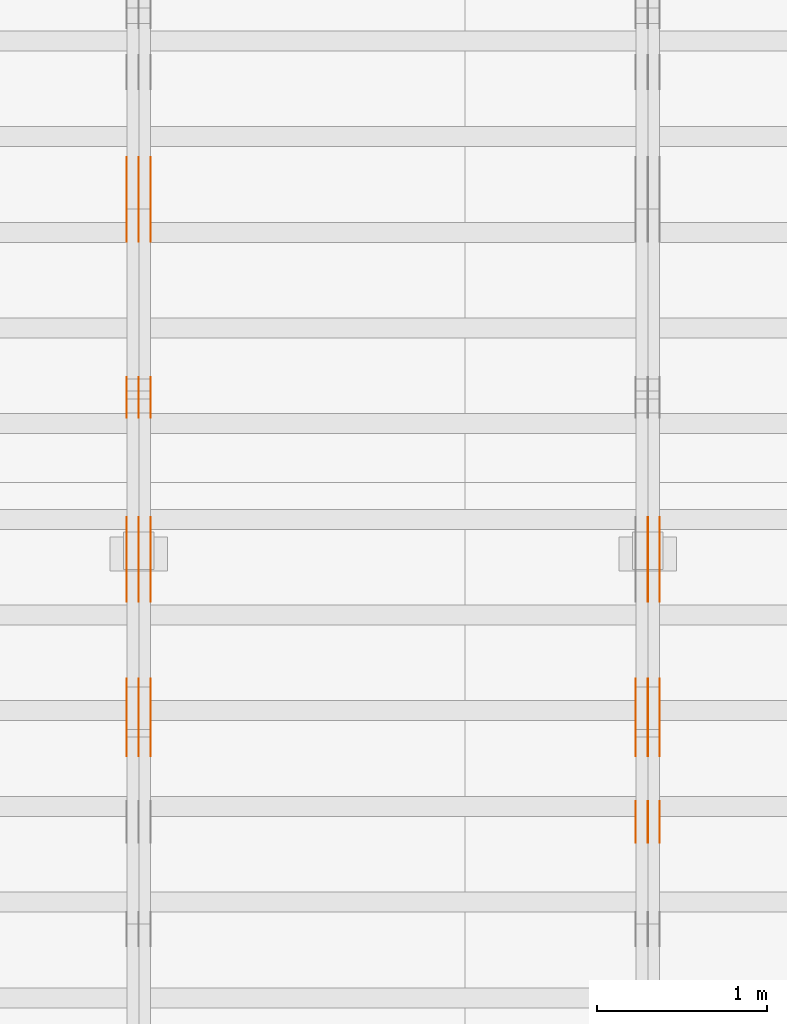
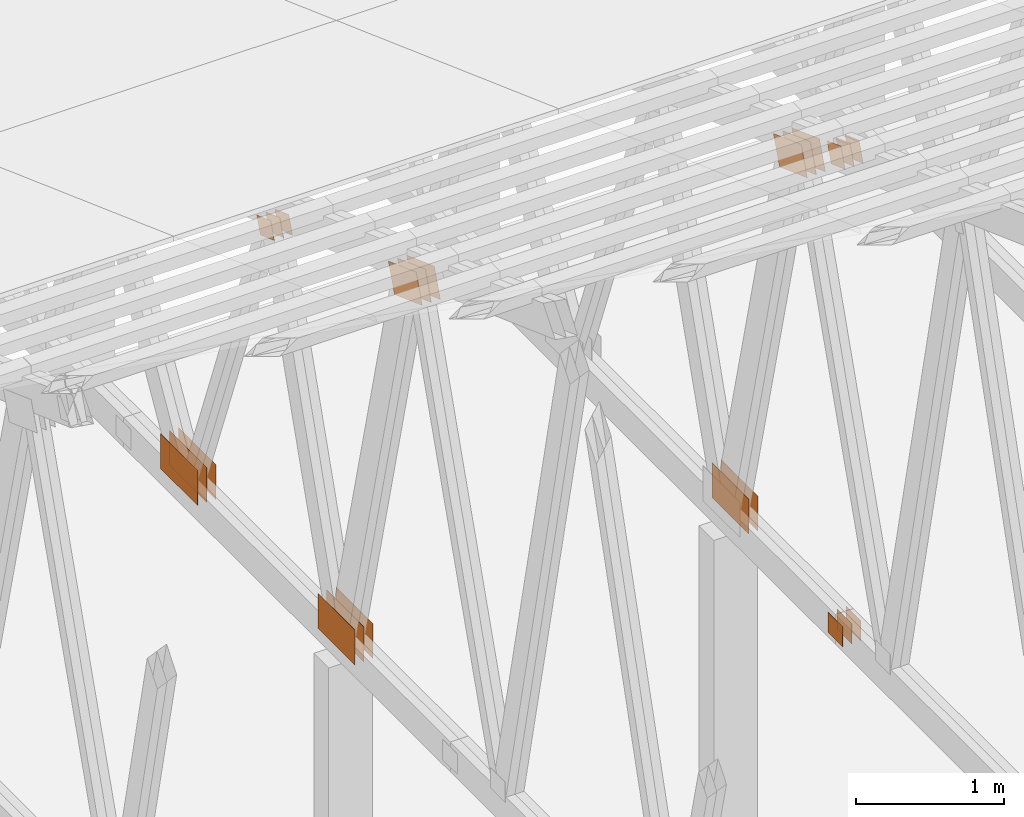
# One storey, part 160 of 189: 31 proxies.
"""IFC2X3 building model written with IfcOpenShell, lengths in millimetres."""

from ifc_helpers import new_model, entity, si_unit, converted_unit, derived_unit, direction, frame, origin, origin_2d_with_axis, place, context, subcontext, project, spatial, polyline, rectangle, outline, extrude, source, transform, mapped, material, type_object, type_shapes, element, save


model = new_model("IFC2X3")

# Units and contexts
model_context = context("Model", 3, precision=0.01, world=origin(), true_north=direction((6.12303176911189e-17, 1.0)))
body_context = subcontext(model_context, "Body", "Model", "MODEL_VIEW")
ifc_project = project(units=[si_unit("LENGTHUNIT", "METRE", prefix="MILLI"), si_unit("AREAUNIT", "SQUARE_METRE"), si_unit("VOLUMEUNIT", "CUBIC_METRE"), converted_unit("PLANEANGLEUNIT", "DEGREE", entity("IfcRatioMeasure", 0.0174532925199433), si_unit("PLANEANGLEUNIT", "RADIAN"), dimensions=[0, 0, 0, 0, 0, 0, 0]), si_unit("MASSUNIT", "GRAM", prefix="KILO"), derived_unit("MASSDENSITYUNIT", [(si_unit("MASSUNIT", "GRAM", prefix="KILO"), 1), (si_unit("LENGTHUNIT", "METRE"), -3)]), si_unit("TIMEUNIT", "SECOND"), si_unit("FREQUENCYUNIT", "HERTZ"), si_unit("THERMODYNAMICTEMPERATUREUNIT", "DEGREE_CELSIUS"), derived_unit("THERMALTRANSMITTANCEUNIT", [(si_unit("MASSUNIT", "GRAM", prefix="KILO"), 1), (si_unit("THERMODYNAMICTEMPERATUREUNIT", "KELVIN"), -1), (si_unit("TIMEUNIT", "SECOND"), -3)]), derived_unit("VOLUMETRICFLOWRATEUNIT", [(si_unit("LENGTHUNIT", "METRE"), 3), (si_unit("TIMEUNIT", "SECOND"), -1)]), si_unit("ELECTRICCURRENTUNIT", "AMPERE"), si_unit("ELECTRICVOLTAGEUNIT", "VOLT"), si_unit("POWERUNIT", "WATT"), si_unit("FORCEUNIT", "NEWTON"), si_unit("ILLUMINANCEUNIT", "LUX"), si_unit("LUMINOUSFLUXUNIT", "LUMEN"), si_unit("LUMINOUSINTENSITYUNIT", "CANDELA"), derived_unit("USERDEFINED", [(si_unit("MASSUNIT", "GRAM", prefix="KILO"), -1), (si_unit("LENGTHUNIT", "METRE"), -2), (si_unit("TIMEUNIT", "SECOND"), 3), (si_unit("LUMINOUSFLUXUNIT", "LUMEN"), 1)]), derived_unit("LINEARVELOCITYUNIT", [(si_unit("LENGTHUNIT", "METRE"), 1), (si_unit("TIMEUNIT", "SECOND"), -1)]), si_unit("PRESSUREUNIT", "PASCAL"), derived_unit("USERDEFINED", [(si_unit("LENGTHUNIT", "METRE"), -2), (si_unit("MASSUNIT", "GRAM", prefix="KILO"), 1), (si_unit("TIMEUNIT", "SECOND"), -2)])], contexts=[model_context])

# Site, building, storey
site_placement = place(None, origin())
site = spatial("IfcSite", under=ifc_project, at=site_placement, CompositionType="ELEMENT")
building_placement = place(site_placement, origin())
building = spatial("IfcBuilding", under=site, at=building_placement, CompositionType="ELEMENT")
storey_placement = place(building_placement, origin())
storey = spatial("IfcBuildingStorey", under=building, at=storey_placement, Name="Default", CompositionType="ELEMENT", Elevation=0.0)

# Proxies
ifc_material_1 = material(Name="IfcSurfaceStyle #202814")
building_element_proxy_type_1 = type_object("IfcBuildingElementProxyType", PredefinedType="NOTDEFINED", material=ifc_material_1)
shared_shape_1 = source(origin(), body_context, "Body", "SweptSolid", [
    extrude(outline(polyline([(-200.000344770935, -119.999765965113), (199.999582244654, -119.999765965113), (200.000344770935, 119.999765965113), (-199.999582244653, 119.999765965113), (-200.000344770935, -119.999765965113)])), frame((200.000344770935, 119.999990805307, 0.0), z_axis=(0.0, 0.0, 1.0), x_axis=(-1.0, 0.0, 0.0)), (0.0, 0.0, 1.0), 1.29999999999999),
])
type_shapes(building_element_proxy_type_1, [shared_shape_1])
proxy_1_placement = place(building_placement, frame((36301.3, 19620.1777846684, 3837.77137841443), z_axis=(-1.0, 0.0, 0.0), x_axis=(0.0, 0.939692620785908, -0.342020143325669)))
element("IfcBuildingElementProxy", 1, at=proxy_1_placement, inside=storey, type_object=building_element_proxy_type_1, material=ifc_material_1, context=body_context, shape_type="MappedRepresentation", body=[
    mapped(shared_shape_1, transform((0.0, 0.0, 0.0), scale=1.0)),
])
ifc_material_2 = material(Name="IfcSurfaceStyle #202757")
building_element_proxy_type_2 = type_object("IfcBuildingElementProxyType", PredefinedType="NOTDEFINED", material=ifc_material_2)
shared_shape_2 = source(origin(), body_context, "Body", "SweptSolid", [
    extrude(outline(polyline([(-200.000344770935, -119.999765965113), (199.999582244654, -119.999765965113), (200.000344770935, 119.999765965113), (-199.999582244653, 119.999765965113), (-200.000344770935, -119.999765965113)])), frame((200.000344770935, 119.999990805307, 0.0), z_axis=(0.0, 0.0, 1.0), x_axis=(-1.0, 0.0, 0.0)), (0.0, 0.0, 1.0), 1.29999999999997),
])
type_shapes(building_element_proxy_type_2, [shared_shape_2])
proxy_2_placement = place(building_placement, frame((36230.0, 19620.1777846684, 3837.77137841443), z_axis=(-1.0, 0.0, 0.0), x_axis=(0.0, 0.939692620785908, -0.342020143325669)))
element("IfcBuildingElementProxy", 2, at=proxy_2_placement, inside=storey, type_object=building_element_proxy_type_2, material=ifc_material_2, context=body_context, shape_type="MappedRepresentation", body=[
    mapped(shared_shape_2, transform((0.0, 0.0, 0.0), scale=1.0)),
])
ifc_material_3 = material(Name="IfcSurfaceStyle #202700")
building_element_proxy_type_3 = type_object("IfcBuildingElementProxyType", PredefinedType="NOTDEFINED", material=ifc_material_3)
shared_shape_3 = source(origin(), body_context, "Body", "SweptSolid", [
    extrude(outline(polyline([(-200.000344770935, -119.999765965113), (199.999582244654, -119.999765965113), (200.000344770935, 119.999765965113), (-199.999582244653, 119.999765965113), (-200.000344770935, -119.999765965113)])), frame((200.000344770935, 119.999990805307, 0.0), z_axis=(0.0, 0.0, 1.0), x_axis=(-1.0, 0.0, 0.0)), (0.0, 0.0, 1.0), 1.29999999999997),
])
type_shapes(building_element_proxy_type_3, [shared_shape_3])
proxy_3_placement = place(building_placement, frame((36231.3, 19620.1777846684, 3837.77137841443), z_axis=(-1.0, 0.0, 0.0), x_axis=(0.0, 0.939692620785908, -0.342020143325669)))
element("IfcBuildingElementProxy", 3, at=proxy_3_placement, inside=storey, type_object=building_element_proxy_type_3, material=ifc_material_3, context=body_context, shape_type="MappedRepresentation", body=[
    mapped(shared_shape_3, transform((0.0, 0.0, 0.0), scale=1.0)),
])
ifc_material_4 = material(Name="IfcSurfaceStyle #202643")
building_element_proxy_type_4 = type_object("IfcBuildingElementProxyType", PredefinedType="NOTDEFINED", material=ifc_material_4)
shared_shape_4 = source(origin(), body_context, "Body", "SweptSolid", [
    extrude(outline(polyline([(-200.000344770935, -119.999765965113), (199.999582244654, -119.999765965113), (200.000344770935, 119.999765965113), (-199.999582244653, 119.999765965113), (-200.000344770935, -119.999765965113)])), frame((200.000344770935, 119.999990805307, 0.0), z_axis=(0.0, 0.0, 1.0), x_axis=(-1.0, 0.0, 0.0)), (0.0, 0.0, 1.0), 1.29999999999998),
])
type_shapes(building_element_proxy_type_4, [shared_shape_4])
proxy_4_placement = place(building_placement, frame((36160.0, 19620.1777846684, 3837.77137841443), z_axis=(-1.0, 0.0, 0.0), x_axis=(0.0, 0.939692620785908, -0.342020143325669)))
element("IfcBuildingElementProxy", 4, at=proxy_4_placement, inside=storey, type_object=building_element_proxy_type_4, material=ifc_material_4, context=body_context, shape_type="MappedRepresentation", body=[
    mapped(shared_shape_4, transform((0.0, 0.0, 0.0), scale=1.0)),
])
ifc_material_5 = material(Name="IfcSurfaceStyle #202586")
building_element_proxy_type_5 = type_object("IfcBuildingElementProxyType", PredefinedType="NOTDEFINED", material=ifc_material_5)
shared_shape_5 = source(origin(), body_context, "Body", "SweptSolid", [
    extrude(rectangle(XDim=500.0, YDim=288.0, at=origin_2d_with_axis()), frame((250.0, 144.0, 0.0), z_axis=(0.0, 0.0, 1.0), x_axis=(-1.0, 0.0, 0.0)), (0.0, 0.0, 1.0), 1.29999999999998),
])
type_shapes(building_element_proxy_type_5, [shared_shape_5])
proxy_5_placement = place(building_placement, frame((36301.3, 20948.0908203125, 101.0), z_axis=(-1.0, 0.0, 0.0), x_axis=(0.0, -1.0, 0.0)))
element("IfcBuildingElementProxy", 5, at=proxy_5_placement, inside=storey, type_object=building_element_proxy_type_5, material=ifc_material_5, context=body_context, shape_type="MappedRepresentation", body=[
    mapped(shared_shape_5, transform((0.0, 0.0, 0.0), scale=1.0)),
])
ifc_material_6 = material(Name="IfcSurfaceStyle #202529")
building_element_proxy_type_6 = type_object("IfcBuildingElementProxyType", PredefinedType="NOTDEFINED", material=ifc_material_6)
shared_shape_6 = source(origin(), body_context, "Body", "SweptSolid", [
    extrude(rectangle(XDim=500.0, YDim=288.0, at=origin_2d_with_axis()), frame((250.0, 144.0, 0.0), z_axis=(0.0, 0.0, 1.0), x_axis=(-1.0, 0.0, 0.0)), (0.0, 0.0, 1.0), 1.29999999999997),
])
type_shapes(building_element_proxy_type_6, [shared_shape_6])
proxy_6_placement = place(building_placement, frame((36230.0, 20948.0908203125, 101.0), z_axis=(-1.0, 0.0, 0.0), x_axis=(0.0, -1.0, 0.0)))
element("IfcBuildingElementProxy", 6, at=proxy_6_placement, inside=storey, type_object=building_element_proxy_type_6, material=ifc_material_6, context=body_context, shape_type="MappedRepresentation", body=[
    mapped(shared_shape_6, transform((0.0, 0.0, 0.0), scale=1.0)),
])
ifc_material_7 = material(Name="IfcSurfaceStyle #202472")
building_element_proxy_type_7 = type_object("IfcBuildingElementProxyType", PredefinedType="NOTDEFINED", material=ifc_material_7)
shared_shape_7 = source(origin(), body_context, "Body", "SweptSolid", [
    extrude(rectangle(XDim=500.0, YDim=288.0, at=origin_2d_with_axis()), frame((250.0, 144.0, 0.0), z_axis=(0.0, 0.0, 1.0), x_axis=(-1.0, 0.0, 0.0)), (0.0, 0.0, 1.0), 1.29999999999997),
])
type_shapes(building_element_proxy_type_7, [shared_shape_7])
proxy_7_placement = place(building_placement, frame((36231.3, 20948.0908203125, 101.0), z_axis=(-1.0, 0.0, 0.0), x_axis=(0.0, -1.0, 0.0)))
element("IfcBuildingElementProxy", 7, at=proxy_7_placement, inside=storey, type_object=building_element_proxy_type_7, material=ifc_material_7, context=body_context, shape_type="MappedRepresentation", body=[
    mapped(shared_shape_7, transform((0.0, 0.0, 0.0), scale=1.0)),
])
ifc_material_8 = material(Name="IfcSurfaceStyle #197570")
building_element_proxy_type_8 = type_object("IfcBuildingElementProxyType", PredefinedType="NOTDEFINED", material=ifc_material_8)
shared_shape_8 = source(origin(), body_context, "Body", "SweptSolid", [
    extrude(rectangle(XDim=200.0, YDim=168.0, at=origin_2d_with_axis()), frame((100.0, 84.0, 0.0), z_axis=(0.0, 0.0, 1.0), x_axis=(-1.0, 0.0, 0.0)), (0.0, 0.0, 1.0), 1.3),
])
type_shapes(building_element_proxy_type_8, [shared_shape_8])
proxy_8_placement = place(building_placement, frame((36301.3, 19061.7587890625, 206.5), z_axis=(-1.0, 0.0, 0.0), x_axis=(0.0, 1.0, 0.0)))
element("IfcBuildingElementProxy", 8, at=proxy_8_placement, inside=storey, type_object=building_element_proxy_type_8, material=ifc_material_8, context=body_context, shape_type="MappedRepresentation", body=[
    mapped(shared_shape_8, transform((0.0, 0.0, 0.0), scale=1.0)),
])
ifc_material_9 = material(Name="IfcSurfaceStyle #197513")
building_element_proxy_type_9 = type_object("IfcBuildingElementProxyType", PredefinedType="NOTDEFINED", material=ifc_material_9)
shared_shape_9 = source(origin(), body_context, "Body", "SweptSolid", [
    extrude(rectangle(XDim=200.0, YDim=168.0, at=origin_2d_with_axis()), frame((100.0, 84.0, 0.0), z_axis=(0.0, 0.0, 1.0), x_axis=(-1.0, 0.0, 0.0)), (0.0, 0.0, 1.0), 1.29999999999998),
])
type_shapes(building_element_proxy_type_9, [shared_shape_9])
proxy_9_placement = place(building_placement, frame((36230.0, 19061.7587890625, 206.5), z_axis=(-1.0, 0.0, 0.0), x_axis=(0.0, 1.0, 0.0)))
element("IfcBuildingElementProxy", 9, at=proxy_9_placement, inside=storey, type_object=building_element_proxy_type_9, material=ifc_material_9, context=body_context, shape_type="MappedRepresentation", body=[
    mapped(shared_shape_9, transform((0.0, 0.0, 0.0), scale=1.0)),
])
ifc_material_10 = material(Name="IfcSurfaceStyle #197456")
building_element_proxy_type_10 = type_object("IfcBuildingElementProxyType", PredefinedType="NOTDEFINED", material=ifc_material_10)
shared_shape_10 = source(origin(), body_context, "Body", "SweptSolid", [
    extrude(rectangle(XDim=200.0, YDim=168.0, at=origin_2d_with_axis()), frame((100.0, 84.0, 0.0), z_axis=(0.0, 0.0, 1.0), x_axis=(-1.0, 0.0, 0.0)), (0.0, 0.0, 1.0), 1.29999999999998),
])
type_shapes(building_element_proxy_type_10, [shared_shape_10])
proxy_10_placement = place(building_placement, frame((36231.3, 19061.7587890625, 206.5), z_axis=(-1.0, 0.0, 0.0), x_axis=(0.0, 1.0, 0.0)))
element("IfcBuildingElementProxy", 10, at=proxy_10_placement, inside=storey, type_object=building_element_proxy_type_10, material=ifc_material_10, context=body_context, shape_type="MappedRepresentation", body=[
    mapped(shared_shape_10, transform((0.0, 0.0, 0.0), scale=1.0)),
])
ifc_material_11 = material(Name="IfcSurfaceStyle #197399")
building_element_proxy_type_11 = type_object("IfcBuildingElementProxyType", PredefinedType="NOTDEFINED", material=ifc_material_11)
shared_shape_11 = source(origin(), body_context, "Body", "SweptSolid", [
    extrude(rectangle(XDim=200.0, YDim=168.0, at=origin_2d_with_axis()), frame((100.0, 84.0, 0.0), z_axis=(0.0, 0.0, 1.0), x_axis=(-1.0, 0.0, 0.0)), (0.0, 0.0, 1.0), 1.29999999999999),
])
type_shapes(building_element_proxy_type_11, [shared_shape_11])
proxy_11_placement = place(building_placement, frame((36160.0, 19061.7587890625, 206.5), z_axis=(-1.0, 0.0, 0.0), x_axis=(0.0, 1.0, 0.0)))
element("IfcBuildingElementProxy", 11, at=proxy_11_placement, inside=storey, type_object=building_element_proxy_type_11, material=ifc_material_11, context=body_context, shape_type="MappedRepresentation", body=[
    mapped(shared_shape_11, transform((0.0, 0.0, 0.0), scale=1.0)),
])
ifc_material_12 = material(Name="IfcSurfaceStyle #195410")
building_element_proxy_type_12 = type_object("IfcBuildingElementProxyType", PredefinedType="NOTDEFINED", material=ifc_material_12)
shared_shape_12 = source(origin(), body_context, "Body", "SweptSolid", [
    extrude(outline(polyline([(-100.000115120732, -83.9999347094754), (99.9997648860521, -83.9999347094754), (100.000156871236, 83.9999347094753), (-99.9998066365565, 83.9999347094753), (-100.000115120732, -83.9999347094754)])), frame((100.000156871236, 84.0000502182443, 0.0), z_axis=(0.0, 0.0, 1.0), x_axis=(-1.0, 0.0, 0.0)), (0.0, 0.0, 1.0), 1.3),
])
type_shapes(building_element_proxy_type_12, [shared_shape_12])
proxy_12_placement = place(building_placement, frame((36301.3, 19216.0995831719, 3923.28093386695), z_axis=(-1.0, 0.0, 0.0), x_axis=(0.0, -0.939692620785908, 0.342020143325669)))
element("IfcBuildingElementProxy", 12, at=proxy_12_placement, inside=storey, type_object=building_element_proxy_type_12, material=ifc_material_12, context=body_context, shape_type="MappedRepresentation", body=[
    mapped(shared_shape_12, transform((0.0, 0.0, 0.0), scale=1.0)),
])
ifc_material_13 = material(Name="IfcSurfaceStyle #195353")
building_element_proxy_type_13 = type_object("IfcBuildingElementProxyType", PredefinedType="NOTDEFINED", material=ifc_material_13)
shared_shape_13 = source(origin(), body_context, "Body", "SweptSolid", [
    extrude(outline(polyline([(-100.000115120732, -83.9999347094754), (99.9997648860521, -83.9999347094754), (100.000156871236, 83.9999347094753), (-99.9998066365565, 83.9999347094753), (-100.000115120732, -83.9999347094754)])), frame((100.000156871236, 84.0000502182443, 0.0), z_axis=(0.0, 0.0, 1.0), x_axis=(-1.0, 0.0, 0.0)), (0.0, 0.0, 1.0), 1.29999999999998),
])
type_shapes(building_element_proxy_type_13, [shared_shape_13])
proxy_13_placement = place(building_placement, frame((36230.0, 19216.0995831719, 3923.28093386695), z_axis=(-1.0, 0.0, 0.0), x_axis=(0.0, -0.939692620785908, 0.342020143325669)))
element("IfcBuildingElementProxy", 13, at=proxy_13_placement, inside=storey, type_object=building_element_proxy_type_13, material=ifc_material_13, context=body_context, shape_type="MappedRepresentation", body=[
    mapped(shared_shape_13, transform((0.0, 0.0, 0.0), scale=1.0)),
])
ifc_material_14 = material(Name="IfcSurfaceStyle #195296")
building_element_proxy_type_14 = type_object("IfcBuildingElementProxyType", PredefinedType="NOTDEFINED", material=ifc_material_14)
shared_shape_14 = source(origin(), body_context, "Body", "SweptSolid", [
    extrude(outline(polyline([(-100.000115120732, -83.9999347094754), (99.9997648860521, -83.9999347094754), (100.000156871236, 83.9999347094753), (-99.9998066365565, 83.9999347094753), (-100.000115120732, -83.9999347094754)])), frame((100.000156871236, 84.0000502182443, 0.0), z_axis=(0.0, 0.0, 1.0), x_axis=(-1.0, 0.0, 0.0)), (0.0, 0.0, 1.0), 1.29999999999998),
])
type_shapes(building_element_proxy_type_14, [shared_shape_14])
proxy_14_placement = place(building_placement, frame((36231.3, 19216.0995831719, 3923.28093386695), z_axis=(-1.0, 0.0, 0.0), x_axis=(0.0, -0.939692620785908, 0.342020143325669)))
element("IfcBuildingElementProxy", 14, at=proxy_14_placement, inside=storey, type_object=building_element_proxy_type_14, material=ifc_material_14, context=body_context, shape_type="MappedRepresentation", body=[
    mapped(shared_shape_14, transform((0.0, 0.0, 0.0), scale=1.0)),
])
ifc_material_15 = material(Name="IfcSurfaceStyle #195239")
building_element_proxy_type_15 = type_object("IfcBuildingElementProxyType", PredefinedType="NOTDEFINED", material=ifc_material_15)
shared_shape_15 = source(origin(), body_context, "Body", "SweptSolid", [
    extrude(outline(polyline([(-100.000115120732, -83.9999347094754), (99.9997648860521, -83.9999347094754), (100.000156871236, 83.9999347094753), (-99.9998066365565, 83.9999347094753), (-100.000115120732, -83.9999347094754)])), frame((100.000156871236, 84.0000502182443, 0.0), z_axis=(0.0, 0.0, 1.0), x_axis=(-1.0, 0.0, 0.0)), (0.0, 0.0, 1.0), 1.29999999999999),
])
type_shapes(building_element_proxy_type_15, [shared_shape_15])
proxy_15_placement = place(building_placement, frame((36160.0, 19216.0995831719, 3923.28093386695), z_axis=(-1.0, 0.0, 0.0), x_axis=(0.0, -0.939692620785908, 0.342020143325669)))
element("IfcBuildingElementProxy", 15, at=proxy_15_placement, inside=storey, type_object=building_element_proxy_type_15, material=ifc_material_15, context=body_context, shape_type="MappedRepresentation", body=[
    mapped(shared_shape_15, transform((0.0, 0.0, 0.0), scale=1.0)),
])
ifc_material_16 = material(Name="IfcSurfaceStyle #187024")
building_element_proxy_type_16 = type_object("IfcBuildingElementProxyType", PredefinedType="NOTDEFINED", material=ifc_material_16)
shared_shape_16 = source(origin(), body_context, "Body", "SweptSolid", [
    extrude(outline(polyline([(-200.000344770935, -119.999765965113), (199.999582244654, -119.999765965113), (200.000344770935, 119.999765965113), (-199.999582244653, 119.999765965113), (-200.000344770935, -119.999765965113)])), frame((200.000344770935, 119.999990805307, 0.0), z_axis=(0.0, 0.0, 1.0), x_axis=(-1.0, 0.0, 0.0)), (0.0, 0.0, 1.0), 1.29999999999999),
])
type_shapes(building_element_proxy_type_16, [shared_shape_16])
proxy_16_placement = place(building_placement, frame((33301.3, 19620.1777846684, 3837.77137841443), z_axis=(-1.0, 0.0, 0.0), x_axis=(0.0, 0.939692620785908, -0.342020143325669)))
element("IfcBuildingElementProxy", 16, at=proxy_16_placement, inside=storey, type_object=building_element_proxy_type_16, material=ifc_material_16, context=body_context, shape_type="MappedRepresentation", body=[
    mapped(shared_shape_16, transform((0.0, 0.0, 0.0), scale=1.0)),
])
ifc_material_17 = material(Name="IfcSurfaceStyle #186967")
building_element_proxy_type_17 = type_object("IfcBuildingElementProxyType", PredefinedType="NOTDEFINED", material=ifc_material_17)
shared_shape_17 = source(origin(), body_context, "Body", "SweptSolid", [
    extrude(outline(polyline([(-200.000344770935, -119.999765965113), (199.999582244654, -119.999765965113), (200.000344770935, 119.999765965113), (-199.999582244653, 119.999765965113), (-200.000344770935, -119.999765965113)])), frame((200.000344770935, 119.999990805307, 0.0), z_axis=(0.0, 0.0, 1.0), x_axis=(-1.0, 0.0, 0.0)), (0.0, 0.0, 1.0), 1.29999999999997),
])
type_shapes(building_element_proxy_type_17, [shared_shape_17])
proxy_17_placement = place(building_placement, frame((33230.0, 19620.1777846684, 3837.77137841443), z_axis=(-1.0, 0.0, 0.0), x_axis=(0.0, 0.939692620785908, -0.342020143325669)))
element("IfcBuildingElementProxy", 17, at=proxy_17_placement, inside=storey, type_object=building_element_proxy_type_17, material=ifc_material_17, context=body_context, shape_type="MappedRepresentation", body=[
    mapped(shared_shape_17, transform((0.0, 0.0, 0.0), scale=1.0)),
])
ifc_material_18 = material(Name="IfcSurfaceStyle #186910")
building_element_proxy_type_18 = type_object("IfcBuildingElementProxyType", PredefinedType="NOTDEFINED", material=ifc_material_18)
shared_shape_18 = source(origin(), body_context, "Body", "SweptSolid", [
    extrude(outline(polyline([(-200.000344770935, -119.999765965113), (199.999582244654, -119.999765965113), (200.000344770935, 119.999765965113), (-199.999582244653, 119.999765965113), (-200.000344770935, -119.999765965113)])), frame((200.000344770935, 119.999990805307, 0.0), z_axis=(0.0, 0.0, 1.0), x_axis=(-1.0, 0.0, 0.0)), (0.0, 0.0, 1.0), 1.29999999999997),
])
type_shapes(building_element_proxy_type_18, [shared_shape_18])
proxy_18_placement = place(building_placement, frame((33231.3, 19620.1777846684, 3837.77137841443), z_axis=(-1.0, 0.0, 0.0), x_axis=(0.0, 0.939692620785908, -0.342020143325669)))
element("IfcBuildingElementProxy", 18, at=proxy_18_placement, inside=storey, type_object=building_element_proxy_type_18, material=ifc_material_18, context=body_context, shape_type="MappedRepresentation", body=[
    mapped(shared_shape_18, transform((0.0, 0.0, 0.0), scale=1.0)),
])
ifc_material_19 = material(Name="IfcSurfaceStyle #186853")
building_element_proxy_type_19 = type_object("IfcBuildingElementProxyType", PredefinedType="NOTDEFINED", material=ifc_material_19)
shared_shape_19 = source(origin(), body_context, "Body", "SweptSolid", [
    extrude(outline(polyline([(-200.000344770935, -119.999765965113), (199.999582244654, -119.999765965113), (200.000344770935, 119.999765965113), (-199.999582244653, 119.999765965113), (-200.000344770935, -119.999765965113)])), frame((200.000344770935, 119.999990805307, 0.0), z_axis=(0.0, 0.0, 1.0), x_axis=(-1.0, 0.0, 0.0)), (0.0, 0.0, 1.0), 1.29999999999998),
])
type_shapes(building_element_proxy_type_19, [shared_shape_19])
proxy_19_placement = place(building_placement, frame((33160.0, 19620.1777846684, 3837.77137841443), z_axis=(-1.0, 0.0, 0.0), x_axis=(0.0, 0.939692620785908, -0.342020143325669)))
element("IfcBuildingElementProxy", 19, at=proxy_19_placement, inside=storey, type_object=building_element_proxy_type_19, material=ifc_material_19, context=body_context, shape_type="MappedRepresentation", body=[
    mapped(shared_shape_19, transform((0.0, 0.0, 0.0), scale=1.0)),
])
ifc_material_20 = material(Name="IfcSurfaceStyle #186796")
building_element_proxy_type_20 = type_object("IfcBuildingElementProxyType", PredefinedType="NOTDEFINED", material=ifc_material_20)
shared_shape_20 = source(origin(), body_context, "Body", "SweptSolid", [
    extrude(rectangle(XDim=500.0, YDim=288.0, at=origin_2d_with_axis()), frame((250.0, 144.0, 0.0), z_axis=(0.0, 0.0, 1.0), x_axis=(-1.0, 0.0, 0.0)), (0.0, 0.0, 1.0), 1.29999999999998),
])
type_shapes(building_element_proxy_type_20, [shared_shape_20])
proxy_20_placement = place(building_placement, frame((33301.3, 20948.0908203125, 101.0), z_axis=(-1.0, 0.0, 0.0), x_axis=(0.0, -1.0, 0.0)))
element("IfcBuildingElementProxy", 20, at=proxy_20_placement, inside=storey, type_object=building_element_proxy_type_20, material=ifc_material_20, context=body_context, shape_type="MappedRepresentation", body=[
    mapped(shared_shape_20, transform((0.0, 0.0, 0.0), scale=1.0)),
])
ifc_material_21 = material(Name="IfcSurfaceStyle #186739")
building_element_proxy_type_21 = type_object("IfcBuildingElementProxyType", PredefinedType="NOTDEFINED", material=ifc_material_21)
shared_shape_21 = source(origin(), body_context, "Body", "SweptSolid", [
    extrude(rectangle(XDim=500.0, YDim=288.0, at=origin_2d_with_axis()), frame((250.0, 144.0, 0.0), z_axis=(0.0, 0.0, 1.0), x_axis=(-1.0, 0.0, 0.0)), (0.0, 0.0, 1.0), 1.29999999999997),
])
type_shapes(building_element_proxy_type_21, [shared_shape_21])
proxy_21_placement = place(building_placement, frame((33230.0, 20948.0908203125, 101.0), z_axis=(-1.0, 0.0, 0.0), x_axis=(0.0, -1.0, 0.0)))
element("IfcBuildingElementProxy", 21, at=proxy_21_placement, inside=storey, type_object=building_element_proxy_type_21, material=ifc_material_21, context=body_context, shape_type="MappedRepresentation", body=[
    mapped(shared_shape_21, transform((0.0, 0.0, 0.0), scale=1.0)),
])
ifc_material_22 = material(Name="IfcSurfaceStyle #186682")
building_element_proxy_type_22 = type_object("IfcBuildingElementProxyType", PredefinedType="NOTDEFINED", material=ifc_material_22)
shared_shape_22 = source(origin(), body_context, "Body", "SweptSolid", [
    extrude(rectangle(XDim=500.0, YDim=288.0, at=origin_2d_with_axis()), frame((250.0, 144.0, 0.0), z_axis=(0.0, 0.0, 1.0), x_axis=(-1.0, 0.0, 0.0)), (0.0, 0.0, 1.0), 1.29999999999997),
])
type_shapes(building_element_proxy_type_22, [shared_shape_22])
proxy_22_placement = place(building_placement, frame((33231.3, 20948.0908203125, 101.0), z_axis=(-1.0, 0.0, 0.0), x_axis=(0.0, -1.0, 0.0)))
element("IfcBuildingElementProxy", 22, at=proxy_22_placement, inside=storey, type_object=building_element_proxy_type_22, material=ifc_material_22, context=body_context, shape_type="MappedRepresentation", body=[
    mapped(shared_shape_22, transform((0.0, 0.0, 0.0), scale=1.0)),
])
ifc_material_23 = material(Name="IfcSurfaceStyle #186625")
building_element_proxy_type_23 = type_object("IfcBuildingElementProxyType", PredefinedType="NOTDEFINED", material=ifc_material_23)
shared_shape_23 = source(origin(), body_context, "Body", "SweptSolid", [
    extrude(rectangle(XDim=500.0, YDim=288.0, at=origin_2d_with_axis()), frame((250.0, 144.0, 0.0), z_axis=(0.0, 0.0, 1.0), x_axis=(-1.0, 0.0, 0.0)), (0.0, 0.0, 1.0), 1.29999999999997),
])
type_shapes(building_element_proxy_type_23, [shared_shape_23])
proxy_23_placement = place(building_placement, frame((33160.0, 20948.0908203125, 101.0), z_axis=(-1.0, 0.0, 0.0), x_axis=(0.0, -1.0, 0.0)))
element("IfcBuildingElementProxy", 23, at=proxy_23_placement, inside=storey, type_object=building_element_proxy_type_23, material=ifc_material_23, context=body_context, shape_type="MappedRepresentation", body=[
    mapped(shared_shape_23, transform((0.0, 0.0, 0.0), scale=1.0)),
])
ifc_material_24 = material(Name="IfcSurfaceStyle #186112")
building_element_proxy_type_24 = type_object("IfcBuildingElementProxyType", PredefinedType="NOTDEFINED", material=ifc_material_24)
shared_shape_24 = source(origin(), body_context, "Body", "SweptSolid", [
    extrude(outline(polyline([(-100.000279336925, -71.9999636698844), (100.000143005157, -71.9999636698844), (100.00004991978, 71.9999636698844), (-99.9999135880125, 71.9999636698845), (-100.000279336925, -71.9999636698844)])), frame((100.000143005157, 72.0001110824169, 0.0), z_axis=(0.0, 0.0, 1.0), x_axis=(-1.0, 0.0, 0.0)), (0.0, 0.0, 1.0), 1.3),
])
type_shapes(building_element_proxy_type_24, [shared_shape_24])
proxy_24_placement = place(building_placement, frame((33301.3, 21584.0819808932, 3071.51551466861), z_axis=(-1.0, 0.0, 0.0), x_axis=(0.0, 0.939692620785908, -0.342020143325669)))
element("IfcBuildingElementProxy", 24, at=proxy_24_placement, inside=storey, type_object=building_element_proxy_type_24, material=ifc_material_24, context=body_context, shape_type="MappedRepresentation", body=[
    mapped(shared_shape_24, transform((0.0, 0.0, 0.0), scale=1.0)),
])
ifc_material_25 = material(Name="IfcSurfaceStyle #186055")
building_element_proxy_type_25 = type_object("IfcBuildingElementProxyType", PredefinedType="NOTDEFINED", material=ifc_material_25)
shared_shape_25 = source(origin(), body_context, "Body", "SweptSolid", [
    extrude(outline(polyline([(-100.000279336925, -71.9999636698844), (100.000143005157, -71.9999636698844), (100.00004991978, 71.9999636698844), (-99.9999135880125, 71.9999636698845), (-100.000279336925, -71.9999636698844)])), frame((100.000143005157, 72.0001110824169, 0.0), z_axis=(0.0, 0.0, 1.0), x_axis=(-1.0, 0.0, 0.0)), (0.0, 0.0, 1.0), 1.29999999999998),
])
type_shapes(building_element_proxy_type_25, [shared_shape_25])
proxy_25_placement = place(building_placement, frame((33230.0, 21584.0819808932, 3071.51551466861), z_axis=(-1.0, 0.0, 0.0), x_axis=(0.0, 0.939692620785908, -0.342020143325669)))
element("IfcBuildingElementProxy", 25, at=proxy_25_placement, inside=storey, type_object=building_element_proxy_type_25, material=ifc_material_25, context=body_context, shape_type="MappedRepresentation", body=[
    mapped(shared_shape_25, transform((0.0, 0.0, 0.0), scale=1.0)),
])
ifc_material_26 = material(Name="IfcSurfaceStyle #185998")
building_element_proxy_type_26 = type_object("IfcBuildingElementProxyType", PredefinedType="NOTDEFINED", material=ifc_material_26)
shared_shape_26 = source(origin(), body_context, "Body", "SweptSolid", [
    extrude(outline(polyline([(-100.000279336925, -71.9999636698844), (100.000143005157, -71.9999636698844), (100.00004991978, 71.9999636698844), (-99.9999135880125, 71.9999636698845), (-100.000279336925, -71.9999636698844)])), frame((100.000143005157, 72.0001110824169, 0.0), z_axis=(0.0, 0.0, 1.0), x_axis=(-1.0, 0.0, 0.0)), (0.0, 0.0, 1.0), 1.29999999999998),
])
type_shapes(building_element_proxy_type_26, [shared_shape_26])
proxy_26_placement = place(building_placement, frame((33231.3, 21584.0819808932, 3071.51551466861), z_axis=(-1.0, 0.0, 0.0), x_axis=(0.0, 0.939692620785908, -0.342020143325669)))
element("IfcBuildingElementProxy", 26, at=proxy_26_placement, inside=storey, type_object=building_element_proxy_type_26, material=ifc_material_26, context=body_context, shape_type="MappedRepresentation", body=[
    mapped(shared_shape_26, transform((0.0, 0.0, 0.0), scale=1.0)),
])
ifc_material_27 = material(Name="IfcSurfaceStyle #185941")
building_element_proxy_type_27 = type_object("IfcBuildingElementProxyType", PredefinedType="NOTDEFINED", material=ifc_material_27)
shared_shape_27 = source(origin(), body_context, "Body", "SweptSolid", [
    extrude(outline(polyline([(-100.000279336925, -71.9999636698844), (100.000143005157, -71.9999636698844), (100.00004991978, 71.9999636698844), (-99.9999135880125, 71.9999636698845), (-100.000279336925, -71.9999636698844)])), frame((100.000143005157, 72.0001110824169, 0.0), z_axis=(0.0, 0.0, 1.0), x_axis=(-1.0, 0.0, 0.0)), (0.0, 0.0, 1.0), 1.29999999999999),
])
type_shapes(building_element_proxy_type_27, [shared_shape_27])
proxy_27_placement = place(building_placement, frame((33160.0, 21584.0819808932, 3071.51551466861), z_axis=(-1.0, 0.0, 0.0), x_axis=(0.0, 0.939692620785908, -0.342020143325669)))
element("IfcBuildingElementProxy", 27, at=proxy_27_placement, inside=storey, type_object=building_element_proxy_type_27, material=ifc_material_27, context=body_context, shape_type="MappedRepresentation", body=[
    mapped(shared_shape_27, transform((0.0, 0.0, 0.0), scale=1.0)),
])
ifc_material_28 = material(Name="IfcSurfaceStyle #185884")
building_element_proxy_type_28 = type_object("IfcBuildingElementProxyType", PredefinedType="NOTDEFINED", material=ifc_material_28)
shared_shape_28 = source(origin(), body_context, "Body", "SweptSolid", [
    extrude(rectangle(XDim=500.0, YDim=288.000007629395, at=origin_2d_with_axis()), frame((250.000021301719, 144.000006357829, 0.0), z_axis=(0.0, 0.0, 1.0), x_axis=(-1.0, 0.0, 0.0)), (0.0, 0.0, 1.0), 1.29999999999998),
])
type_shapes(building_element_proxy_type_28, [shared_shape_28])
proxy_28_placement = place(building_placement, frame((33301.3, 23069.1650603642, 127.333333333333), z_axis=(-1.0, 0.0, 0.0), x_axis=(0.0, -1.0, 0.0)))
element("IfcBuildingElementProxy", 28, at=proxy_28_placement, inside=storey, type_object=building_element_proxy_type_28, material=ifc_material_28, context=body_context, shape_type="MappedRepresentation", body=[
    mapped(shared_shape_28, transform((0.0, 0.0, 0.0), scale=1.0)),
])
ifc_material_29 = material(Name="IfcSurfaceStyle #185827")
building_element_proxy_type_29 = type_object("IfcBuildingElementProxyType", PredefinedType="NOTDEFINED", material=ifc_material_29)
shared_shape_29 = source(origin(), body_context, "Body", "SweptSolid", [
    extrude(rectangle(XDim=500.0, YDim=288.000007629395, at=origin_2d_with_axis()), frame((250.000021301719, 144.000006357829, 0.0), z_axis=(0.0, 0.0, 1.0), x_axis=(-1.0, 0.0, 0.0)), (0.0, 0.0, 1.0), 1.29999999999997),
])
type_shapes(building_element_proxy_type_29, [shared_shape_29])
proxy_29_placement = place(building_placement, frame((33230.0, 23069.1650603642, 127.333333333333), z_axis=(-1.0, 0.0, 0.0), x_axis=(0.0, -1.0, 0.0)))
element("IfcBuildingElementProxy", 29, at=proxy_29_placement, inside=storey, type_object=building_element_proxy_type_29, material=ifc_material_29, context=body_context, shape_type="MappedRepresentation", body=[
    mapped(shared_shape_29, transform((0.0, 0.0, 0.0), scale=1.0)),
])
ifc_material_30 = material(Name="IfcSurfaceStyle #185770")
building_element_proxy_type_30 = type_object("IfcBuildingElementProxyType", PredefinedType="NOTDEFINED", material=ifc_material_30)
shared_shape_30 = source(origin(), body_context, "Body", "SweptSolid", [
    extrude(rectangle(XDim=500.0, YDim=288.000007629395, at=origin_2d_with_axis()), frame((250.000021301719, 144.000006357829, 0.0), z_axis=(0.0, 0.0, 1.0), x_axis=(-1.0, 0.0, 0.0)), (0.0, 0.0, 1.0), 1.29999999999997),
])
type_shapes(building_element_proxy_type_30, [shared_shape_30])
proxy_30_placement = place(building_placement, frame((33231.3, 23069.1650603642, 127.333333333333), z_axis=(-1.0, 0.0, 0.0), x_axis=(0.0, -1.0, 0.0)))
element("IfcBuildingElementProxy", 30, at=proxy_30_placement, inside=storey, type_object=building_element_proxy_type_30, material=ifc_material_30, context=body_context, shape_type="MappedRepresentation", body=[
    mapped(shared_shape_30, transform((0.0, 0.0, 0.0), scale=1.0)),
])
ifc_material_31 = material(Name="IfcSurfaceStyle #185713")
building_element_proxy_type_31 = type_object("IfcBuildingElementProxyType", PredefinedType="NOTDEFINED", material=ifc_material_31)
shared_shape_31 = source(origin(), body_context, "Body", "SweptSolid", [
    extrude(rectangle(XDim=500.0, YDim=288.000007629395, at=origin_2d_with_axis()), frame((250.000021301719, 144.000006357829, 0.0), z_axis=(0.0, 0.0, 1.0), x_axis=(-1.0, 0.0, 0.0)), (0.0, 0.0, 1.0), 1.29999999999997),
])
type_shapes(building_element_proxy_type_31, [shared_shape_31])
proxy_31_placement = place(building_placement, frame((33160.0, 23069.1650603642, 127.333333333333), z_axis=(-1.0, 0.0, 0.0), x_axis=(0.0, -1.0, 0.0)))
element("IfcBuildingElementProxy", 31, at=proxy_31_placement, inside=storey, type_object=building_element_proxy_type_31, material=ifc_material_31, context=body_context, shape_type="MappedRepresentation", body=[
    mapped(shared_shape_31, transform((0.0, 0.0, 0.0), scale=1.0)),
])

save(model, "model.ifc")
